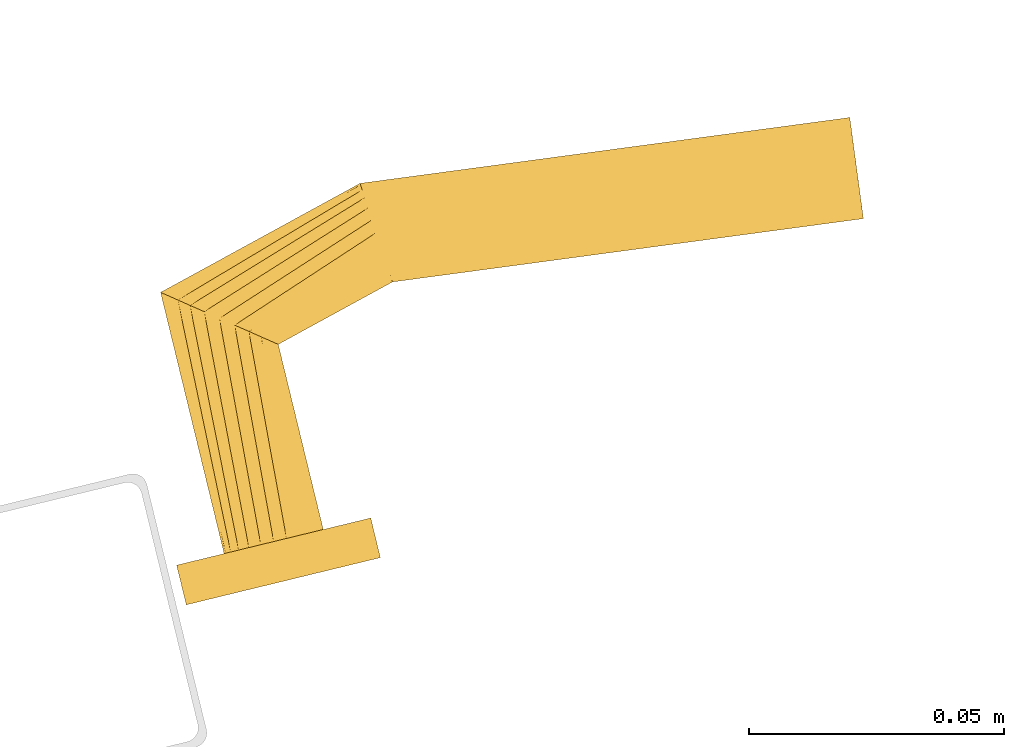
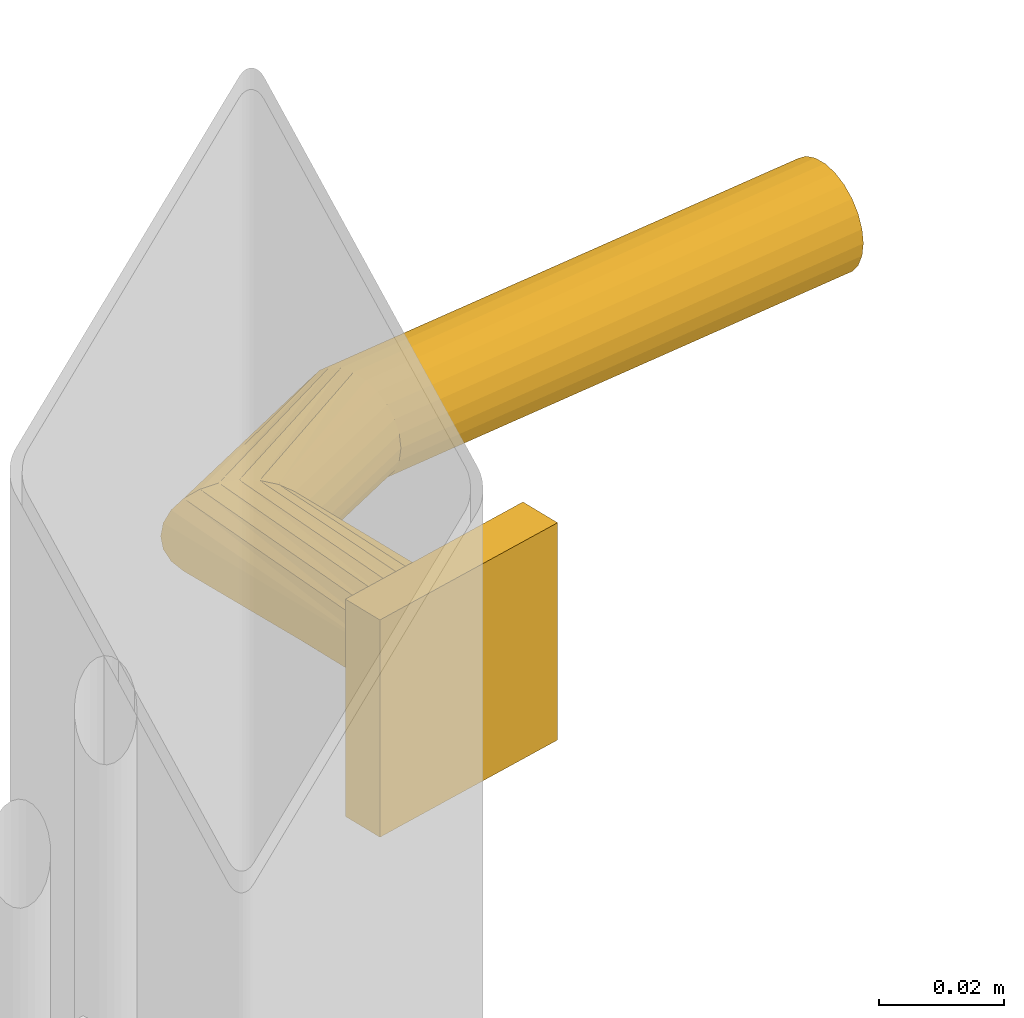
# One storey, part 10 of 10: 1 door.
"""IFC2X3 building model written with IfcOpenShell, lengths in millimetres."""

from ifc_helpers import new_model, entity, si_unit, converted_unit, derived_unit, direction, frame, origin, place, context, subcontext, project, spatial, faceted_brep, source, transform, mapped, material, type_object, type_shapes, element, save


model = new_model("IFC2X3")

# Units and contexts
model_context = context("Model", 3, precision=0.01, world=origin(), true_north=direction((6.12303176911189e-17, 1.0)))
body_context = subcontext(model_context, "Body", "Model", "MODEL_VIEW")
ifc_project = project(units=[si_unit("LENGTHUNIT", "METRE", prefix="MILLI"), si_unit("AREAUNIT", "SQUARE_METRE"), si_unit("VOLUMEUNIT", "CUBIC_METRE"), converted_unit("PLANEANGLEUNIT", "DEGREE", entity("IfcRatioMeasure", 0.0174532925199433), si_unit("PLANEANGLEUNIT", "RADIAN"), dimensions=[0, 0, 0, 0, 0, 0, 0]), si_unit("MASSUNIT", "GRAM", prefix="KILO"), derived_unit("MASSDENSITYUNIT", [(si_unit("MASSUNIT", "GRAM", prefix="KILO"), 1), (si_unit("LENGTHUNIT", "METRE"), -3)]), derived_unit("MOMENTOFINERTIAUNIT", [(si_unit("LENGTHUNIT", "METRE"), 4)]), si_unit("TIMEUNIT", "SECOND"), si_unit("FREQUENCYUNIT", "HERTZ"), si_unit("THERMODYNAMICTEMPERATUREUNIT", "DEGREE_CELSIUS"), derived_unit("THERMALTRANSMITTANCEUNIT", [(si_unit("MASSUNIT", "GRAM", prefix="KILO"), 1), (si_unit("THERMODYNAMICTEMPERATUREUNIT", "KELVIN"), -1), (si_unit("TIMEUNIT", "SECOND"), -3)]), derived_unit("VOLUMETRICFLOWRATEUNIT", [(si_unit("LENGTHUNIT", "METRE"), 3), (si_unit("TIMEUNIT", "SECOND"), -1)]), derived_unit("MASSFLOWRATEUNIT", [(si_unit("MASSUNIT", "GRAM", prefix="KILO"), 1), (si_unit("TIMEUNIT", "SECOND"), -1)]), derived_unit("ROTATIONALFREQUENCYUNIT", [(si_unit("TIMEUNIT", "SECOND"), -1)]), si_unit("ELECTRICCURRENTUNIT", "AMPERE"), si_unit("ELECTRICVOLTAGEUNIT", "VOLT"), si_unit("POWERUNIT", "WATT"), si_unit("FORCEUNIT", "NEWTON", prefix="KILO"), si_unit("ILLUMINANCEUNIT", "LUX"), si_unit("LUMINOUSFLUXUNIT", "LUMEN"), si_unit("LUMINOUSINTENSITYUNIT", "CANDELA"), derived_unit("USERDEFINED", [(si_unit("MASSUNIT", "GRAM", prefix="KILO"), -1), (si_unit("LENGTHUNIT", "METRE"), -2), (si_unit("TIMEUNIT", "SECOND"), 3), (si_unit("LUMINOUSFLUXUNIT", "LUMEN"), 1)]), derived_unit("LINEARVELOCITYUNIT", [(si_unit("LENGTHUNIT", "METRE"), 1), (si_unit("TIMEUNIT", "SECOND"), -1)]), si_unit("PRESSUREUNIT", "PASCAL"), derived_unit("USERDEFINED", [(si_unit("LENGTHUNIT", "METRE"), -2), (si_unit("MASSUNIT", "GRAM", prefix="KILO"), 1), (si_unit("TIMEUNIT", "SECOND"), -2)]), derived_unit("LINEARFORCEUNIT", [(si_unit("MASSUNIT", "GRAM", prefix="KILO"), 1), (si_unit("LENGTHUNIT", "METRE"), 1), (si_unit("TIMEUNIT", "SECOND"), -2), (si_unit("LENGTHUNIT", "METRE"), -1)]), derived_unit("PLANARFORCEUNIT", [(si_unit("MASSUNIT", "GRAM", prefix="KILO"), 1), (si_unit("LENGTHUNIT", "METRE"), 1), (si_unit("TIMEUNIT", "SECOND"), -2), (si_unit("LENGTHUNIT", "METRE"), -2)])], contexts=[model_context])

# Site, building, storey
site_placement = place(None, frame((19171.75, -72498.58, 0.0), z_axis=(0.0, 0.0, 1.0), x_axis=(0.971695960795463, 0.236234967296933, 0.0)))
site = spatial("IfcSite", under=ifc_project, at=site_placement, CompositionType="ELEMENT")
building_placement = place(site_placement, origin())
building = spatial("IfcBuilding", under=site, at=building_placement, CompositionType="ELEMENT")
storey_placement = place(building_placement, origin())
storey = spatial("IfcBuildingStorey", under=building, at=storey_placement, Name="01", CompositionType="ELEMENT", Elevation=0.0)

# Door
ifc_material = material(Name="Metal - Aluminium")
door_style = type_object("IfcDoorStyle", Name="Handle (6):Handle (6)", ConstructionType="NOTDEFINED", OperationType="NOTDEFINED", ParameterTakesPrecedence=False, Sizeable=False, material=ifc_material)
shared_shape = source(origin(), body_context, "Body", "Brep", [
    faceted_brep([(222.41, 8.0, -9.66), (225.0, 8.0, -10.0), (227.59, 8.0, -9.66), (230.0, 8.0, -8.66), (232.07, 8.0, -7.07), (233.66, 8.0, -5.0), (234.66, 8.0, -2.59), (235.0, 8.0, 0.0), (234.66, 8.0, 2.59), (233.66, 8.0, 5.0), (232.07, 8.0, 7.07), (230.0, 8.0, 8.66), (227.59, 8.0, 9.66), (225.0, 8.0, 10.0), (222.41, 8.0, 9.66), (220.0, 8.0, 8.66), (217.93, 8.0, 7.07), (216.34, 8.0, 5.0), (215.34, 8.0, 2.59), (215.0, 8.0, 0.0), (215.34, 8.0, -2.59), (216.34, 8.0, -5.0), (217.93, 8.0, -7.07), (220.0, 8.0, -8.66), (215.0, 60.67, 0.0), (215.34, 60.41, -2.59), (216.34, 59.65, -5.0), (217.93, 58.43, -7.07), (220.0, 56.84, -8.66), (222.41, 54.99, -9.66), (225.0, 53.0, -10.0), (227.59, 51.01, -9.66), (230.0, 49.16, -8.66), (232.07, 47.57, -7.07), (234.66, 45.59, -2.59), (235.0, 45.33, 0.0), (233.66, 46.35, -5.0), (233.66, 46.35, 5.0), (232.07, 47.57, 7.07), (234.66, 45.59, 2.59), (230.0, 49.16, 8.66), (227.59, 51.01, 9.66), (225.0, 53.0, 10.0), (220.0, 56.84, 8.66), (222.41, 54.99, 9.66), (217.93, 58.43, 7.07), (216.34, 59.65, 5.0), (215.34, 60.41, 2.59), (258.01, 72.2, 0.0), (258.04, 71.85, -2.59), (258.12, 70.84, -5.0), (258.24, 69.23, -7.07), (258.41, 67.13, -8.66), (258.6, 64.68, -9.66), (258.81, 62.06, -10.0), (259.21, 56.99, -8.66), (259.37, 54.89, -7.07), (259.01, 59.43, -9.66), (259.58, 52.27, -2.59), (259.61, 51.92, 0.0), (259.5, 53.28, -5.0), (259.5, 53.28, 5.0), (259.37, 54.89, 7.07), (259.58, 52.27, 2.59), (259.01, 59.43, 9.66), (258.81, 62.06, 10.0), (259.21, 56.99, 8.66), (258.6, 64.68, 9.66), (258.41, 67.13, 8.66), (258.24, 69.23, 7.07), (258.12, 70.84, 5.0), (258.04, 71.85, 2.59), (353.53, 54.7, -9.66), (353.78, 57.1, -8.66), (354.0, 59.16, -7.07), (354.17, 60.74, -5.0), (354.27, 61.73, -2.59), (354.31, 62.07, 0.0), (354.27, 61.73, 2.59), (354.17, 60.74, 5.0), (354.0, 59.16, 7.07), (353.78, 57.1, 8.66), (353.53, 54.7, 9.66), (353.26, 52.13, 10.0), (352.99, 49.55, 9.66), (352.74, 47.16, 8.66), (352.52, 45.1, 7.07), (352.36, 43.52, 5.0), (352.25, 42.52, 2.59), (352.22, 42.18, 0.0), (352.25, 42.52, -2.59), (352.36, 43.52, -5.0), (352.52, 45.1, -7.07), (352.74, 47.16, -8.66), (352.99, 49.55, -9.66), (353.26, 52.13, -10.0)], [[[0, 1, 2, 3, 4, 5, 6, 7, 8, 9, 10, 11, 12, 13, 14, 15, 16, 17, 18, 19, 20, 21, 22, 23]], [[19, 24, 25, 20]], [[26, 20, 25]], [[21, 27, 28]], [[26, 27, 20]], [[22, 28, 29]], [[27, 21, 20]], [[0, 30, 31]], [[30, 0, 23]], [[22, 29, 23]], [[22, 21, 28]], [[29, 30, 23]], [[32, 33, 2]], [[31, 32, 1]], [[34, 35, 7, 6]], [[36, 34, 6, 5]], [[33, 36, 5, 4]], [[33, 3, 2]], [[2, 1, 32]], [[4, 3, 33]], [[31, 1, 0]], [[37, 38, 10, 9]], [[39, 37, 9, 8]], [[13, 40, 41]], [[12, 40, 13]], [[38, 40, 12]], [[35, 39, 8, 7]], [[11, 10, 38]], [[38, 12, 11]], [[41, 42, 14]], [[43, 16, 44]], [[45, 17, 43]], [[18, 46, 47]], [[45, 46, 18]], [[19, 18, 47, 24]], [[15, 14, 42]], [[13, 41, 14]], [[18, 17, 45]], [[16, 43, 17]], [[16, 15, 44]], [[42, 44, 15]], [[25, 24, 48, 49]], [[50, 27, 49]], [[29, 51, 52]], [[50, 51, 28]], [[30, 29, 52]], [[49, 26, 25]], [[31, 53, 54]], [[29, 28, 51]], [[27, 50, 28]], [[27, 26, 49]], [[52, 53, 30]], [[55, 56, 33, 32]], [[57, 55, 32]], [[58, 59, 35, 34]], [[60, 58, 34, 36]], [[56, 60, 36, 33]], [[30, 53, 31]], [[31, 54, 32]], [[54, 57, 32]], [[61, 62, 38, 37]], [[63, 61, 37, 39]], [[64, 65, 40]], [[66, 64, 40]], [[62, 66, 40, 38]], [[63, 39, 35, 59]], [[65, 41, 40]], [[65, 67, 41]], [[68, 42, 67]], [[69, 44, 68]], [[45, 70, 71]], [[69, 70, 43]], [[47, 71, 48, 24]], [[69, 43, 44]], [[44, 42, 68]], [[45, 71, 46]], [[47, 46, 71]], [[43, 70, 45]], [[67, 42, 41]], [[72, 73, 74, 75, 76, 77, 78, 79, 80, 81, 82, 83, 84, 85, 86, 87, 88, 89, 90, 91, 92, 93, 94, 95]], [[76, 49, 48, 77]], [[75, 50, 49, 76]], [[52, 51, 74, 73]], [[75, 74, 51, 50]], [[53, 52, 73, 72]], [[54, 53, 72, 95]], [[55, 57, 94, 93]], [[92, 56, 55, 93]], [[90, 89, 59, 58]], [[60, 56, 92, 91]], [[58, 60, 91, 90]], [[54, 95, 94, 57]], [[88, 63, 59, 89]], [[87, 61, 63, 88]], [[62, 86, 85, 66]], [[87, 86, 62, 61]], [[66, 85, 84, 64]], [[83, 65, 64, 84]], [[81, 68, 67, 82]], [[80, 69, 68, 81]], [[70, 79, 78, 71]], [[80, 79, 70, 69]], [[71, 78, 77, 48]], [[67, 65, 83, 82]]]),
    faceted_brep([(205.43, 8.0, 19.06), (244.57, 8.0, 19.06), (244.57, 8.0, -23.22), (205.43, 8.0, -23.22), (205.43, 0.0, 19.06), (205.43, 0.0, -23.22), (244.57, 0.0, -23.22), (244.57, 0.0, 19.06)], [[[0, 1, 2, 3]], [[4, 5, 6, 7]], [[1, 0, 4, 7]], [[2, 1, 7, 6]], [[3, 2, 6, 5]], [[0, 3, 5, 4]]]),
])
type_shapes(door_style, [shared_shape])
door_placement = place(storey_placement, frame((4224.0, 5600.0, 828.31)))
element("IfcDoor", 1, at=door_placement, inside=storey, type_object=door_style, material=ifc_material, Name="Handle (6):Handle (6)", ObjectType="Handle (6):Handle (6)", OverallHeight=42.2769002288064, OverallWidth=204.30694430893, context=body_context, shape_type="MappedRepresentation", body=[
    mapped(shared_shape, transform((0.0, 0.0, 0.0), scale=1.0)),
])

save(model, "model.ifc")
